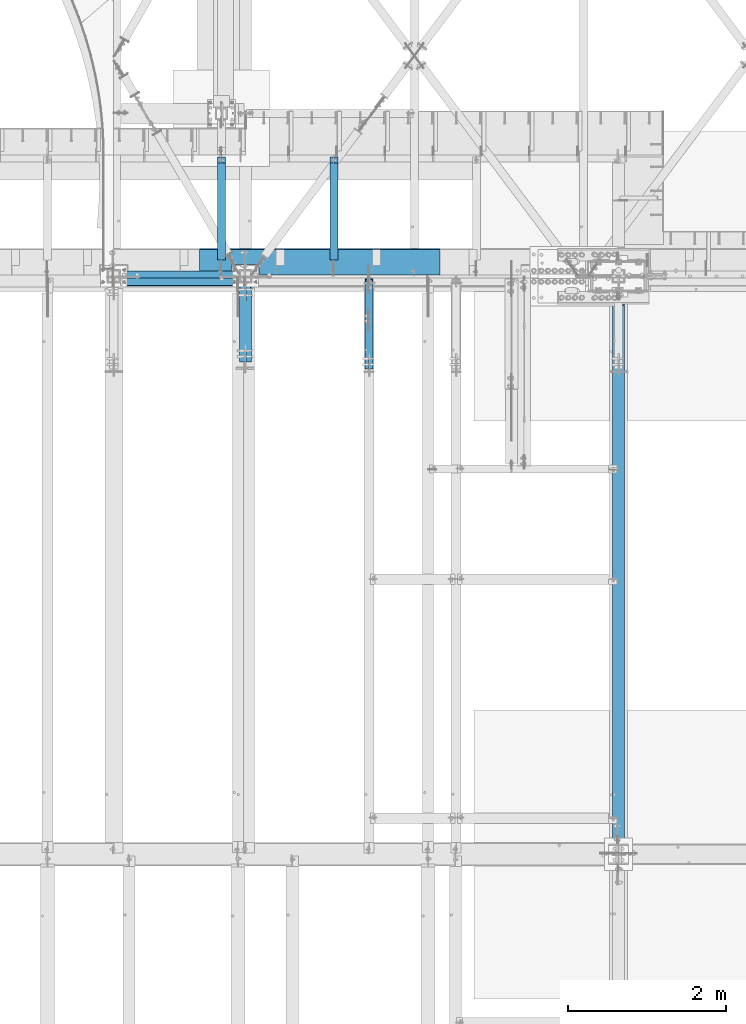
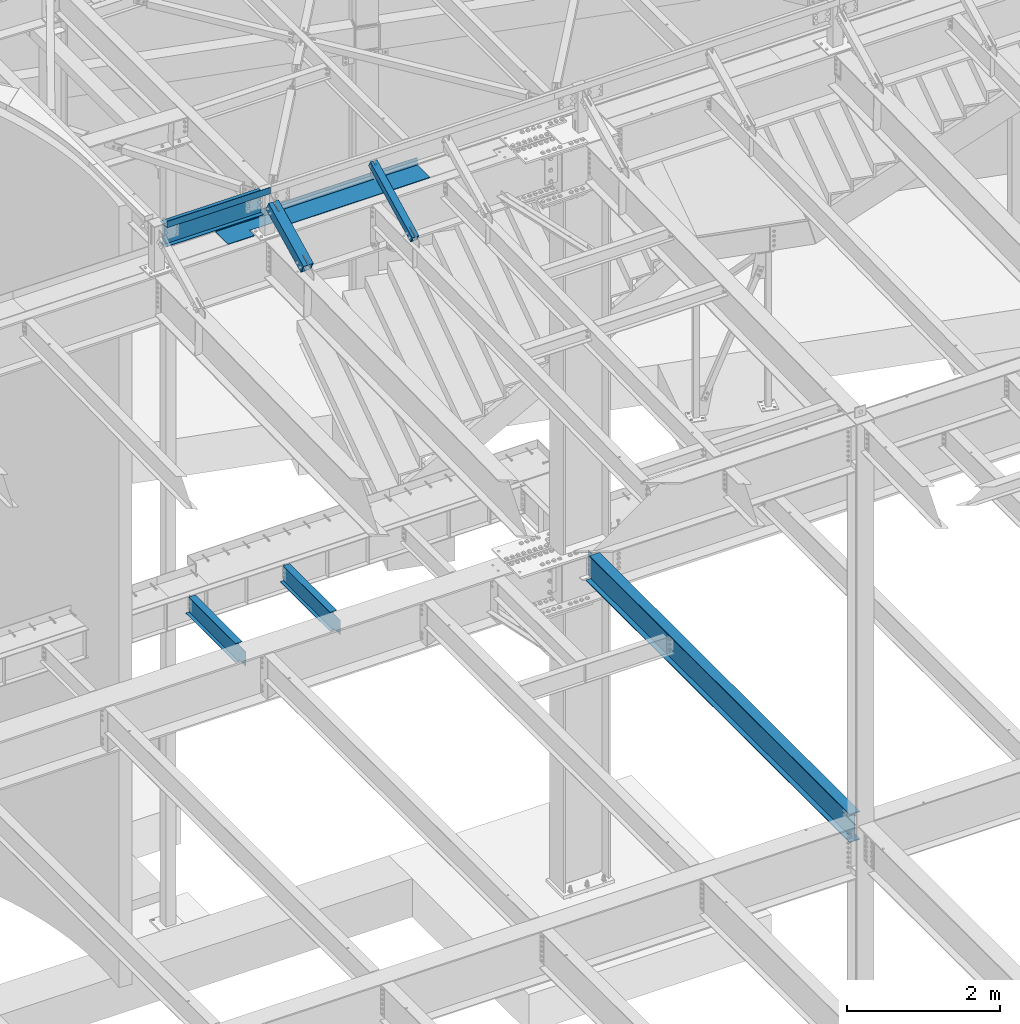
# One storey, part 1144 of 1763: 6 beams, 2 members, 7 elements without a shape of their own.
"""IFC2X3 building model written with IfcOpenShell, lengths in millimetres."""

from ifc_helpers import new_model, si_unit, frame, origin_with_axes, place, context, subcontext, project, spatial, faceted_brep, material, type_object, element, aggregate, save


model = new_model("IFC2X3")

# Units and contexts
model_context = context("Model", 3, precision=1e-05, world=origin_with_axes())
body_context = subcontext(model_context, "Body", "Model", "MODEL_VIEW")
ifc_project = project(units=[si_unit("LENGTHUNIT", "METRE", prefix="MILLI"), si_unit("AREAUNIT", "SQUARE_METRE"), si_unit("VOLUMEUNIT", "CUBIC_METRE"), si_unit("MASSUNIT", "GRAM", prefix="KILO"), si_unit("TIMEUNIT", "SECOND"), si_unit("PLANEANGLEUNIT", "RADIAN"), si_unit("SOLIDANGLEUNIT", "STERADIAN"), si_unit("THERMODYNAMICTEMPERATUREUNIT", "DEGREE_CELSIUS"), si_unit("LUMINOUSINTENSITYUNIT", "LUMEN")], contexts=[model_context])

# Site, building, storey
site_placement = place(None, origin_with_axes())
site = spatial("IfcSite", under=ifc_project, at=site_placement, CompositionType="ELEMENT")
building_placement = place(site_placement, origin_with_axes())
building = spatial("IfcBuilding", under=site, at=building_placement, Name="Undefined", CompositionType="ELEMENT")
storey_placement = place(building_placement, origin_with_axes())
storey = spatial("IfcBuildingStorey", under=building, at=storey_placement, Name="Undefined", CompositionType="ELEMENT", Elevation=0.0)

# Assembly, beam
assembly_1_placement = place(storey_placement, origin_with_axes())
assembly_1 = element("IfcElementAssembly", 1, at=assembly_1_placement, inside=storey, Name="BEAM", AssemblyPlace="NOTDEFINED", PredefinedType="RIGID_FRAME")
ifc_material_1 = material(Name="STEEL/A36")
beam_type_1 = type_object("IfcBeamType", PredefinedType="NOTDEFINED")
beam_1_placement = place(assembly_1_placement, frame((-40470.4887217781, 52101.75, 12449.175), z_axis=(-1.0, 0.0, 0.0), x_axis=(0.0, -1.0, 0.0)))
beam_1 = element("IfcBeam", 2, at=beam_1_placement, type_object=beam_type_1, material=ifc_material_1, Name="BENT_PLATE", context=body_context, shape_type="Brep", body=[
    faceted_brep([(0.0, -3.17499999999927, -779.1495), (0.0, -3.17499999999927, 779.1495), (0.0, 3.17499999999927, 779.1495), (0.0, 3.17499999999927, -779.1495), (95.2499984741153, 3.17499999999927, 779.1495), (95.2499984741153, 3.17499999999927, -779.1495), (101.599998474121, -3.17499999999927, -779.1495), (101.599998474121, -3.17499999999927, 779.1495), (95.2499984741153, 98.4249984741218, 779.1495), (95.2499984741153, 98.4249984741218, -779.1495), (101.599998474121, 98.4249984741218, 779.1495), (101.599998474121, 98.4249984741218, -779.1495)], [[[0, 1, 2, 3]], [[3, 2, 4, 5]], [[1, 0, 6, 7]], [[5, 4, 8, 9]], [[4, 2, 1, 7, 10, 8]], [[7, 6, 11, 10]], [[6, 0, 3, 5, 9, 11]], [[10, 11, 9, 8]]]),
])

# Assembly, member
assembly_2_placement = place(storey_placement, origin_with_axes())
assembly_2 = element("IfcElementAssembly", 3, at=assembly_2_placement, inside=storey, Name="BEAM", AssemblyPlace="NOTDEFINED", PredefinedType="RIGID_FRAME")
ifc_material_2 = material()
member_type_1 = type_object("IfcMemberType", Name="HSS4X4X1/2", PredefinedType="NOTDEFINED")
member_1_placement = place(assembly_2_placement, frame((-38107.8885203322, 50822.4762411655, 11720.6381213767), z_axis=(-1.0, 0.0, 0.0), x_axis=(0.0, 0.894427191199916, 0.447213595099959)))
member_1 = element("IfcMember", 4, at=member_1_placement, type_object=member_type_1, material=ifc_material_2, Name="BEAM", ObjectType="HSS4X4X1/2", context=body_context, shape_type="Brep", body=[
    faceted_brep([(166.342448712421, -50.8000000002612, 7.93750000025466), (166.342448712407, -38.100000000255, 7.93750000025466), (317.154945941751, -38.1000000004733, 7.93750000025466), (317.154945941787, -50.8000000004795, 7.93750000025466), (320.192495686126, -38.1000000004788, 7.33329378956478), (320.192495686155, -50.8000000004849, 7.33329378956478), (322.767606017376, -38.1000000004806, 5.61266007592349), (322.767606017405, -50.8000000004849, 5.61266007592349), (324.488239731007, -38.1000000004842, 3.03754974465119), (324.488239731028, -50.800000000494, 3.03754974465119), (317.154945941773, -50.8000000004795, -7.93749999987267), (317.154945941751, -38.1000000004715, -7.93749999987267), (166.342448712407, -38.100000000255, -7.93749999974898), (166.342448712421, -50.8000000002612, -7.93749999974898), (320.192495686155, -50.8000000004831, -7.33329378918279), (320.192495686126, -38.1000000004769, -7.33329378918279), (322.767606017391, -50.8000000004868, -5.61266007554514), (322.767606017376, -38.1000000004806, -5.61266007554514), (324.488239731028, -50.800000000494, -3.03754974427284), (324.488239731007, -38.1000000004842, -3.03754974427284), (325.092445941715, -50.8000000004904, 2.5465851649642e-10), (325.092445941693, -38.1000000004842, 2.5465851649642e-10), (166.342448712276, 38.0999999997875, 7.93750000025466), (166.342448712254, 50.7999999997955, 7.93750000025466), (317.154945941591, 50.7999999995791, 7.93750000025466), (317.15494594162, 38.0999999995711, 7.93750000025466), (320.192495685966, 50.7999999995736, 7.33329378956478), (320.192495685995, 38.0999999995693, 7.33329378956478), (322.767606017216, 50.7999999995718, 5.61266007592349), (322.767606017245, 38.0999999995638, 5.61266007592349), (324.488239730847, 50.7999999995682, 3.03754974465119), (324.488239730868, 38.0999999995638, 3.03754974465119), (317.154945941606, 38.0999999995693, -7.93749999987267), (317.154945941591, 50.7999999995791, -7.93749999987267), (166.342448712254, 50.7999999997955, -7.93749999974898), (166.342448712276, 38.0999999997875, -7.93749999974898), (320.19249568598, 38.0999999995674, -7.33329378918279), (320.192495685966, 50.7999999995754, -7.33329378918279), (322.767606017245, 38.0999999995638, -5.61266007554514), (322.767606017209, 50.79999999957, -5.61266007554514), (324.488239730861, 38.0999999995602, -3.03754974427284), (324.488239730847, 50.7999999995682, -3.03754974427284), (325.092445941555, 38.0999999995583, 2.5465851649642e-10), (325.092445941533, 50.7999999995682, 2.5465851649642e-10), (166.342448712407, -38.100000000255, 38.0999999999985), (166.342448712276, 38.0999999997875, 38.0999999999985), (1394.22226894266, 38.0999999980304, 38.0999999999985), (1394.2222689429, -38.1000000020122, 38.0999999999985), (1277.08025779721, 50.7999999982076, -7.9375), (1394.22226894262, 50.799999998042, -7.9375), (1394.22226894262, 50.799999998042, -50.7999999999993), (166.342448712254, 50.7999999997955, -50.7999999999993), (166.342448712254, 50.7999999997955, 50.7999999999993), (1394.22226894262, 50.799999998042, 50.7999999999993), (1394.22226894262, 50.799999998042, 7.9375), (1277.08025779721, 50.7999999982076, 7.9375), (1394.22226894266, 38.0999999980304, 7.9375), (1283.4302577901, 38.0999999981887, 7.9375), (1283.4302577901, 38.0999999981887, -7.9375), (1394.22226894266, 38.0999999980304, -7.9375), (166.342448712276, 38.0999999997875, -38.0999999999985), (166.342448712407, -38.100000000255, -38.0999999999985), (1394.2222689429, -38.1000000020122, -38.0999999999985), (1394.22226894266, 38.0999999980304, -38.0999999999985), (1327.88025774027, -50.8000000019219, -7.9375), (1321.53025774739, -38.1000000019103, -7.9375), (1321.53025774739, -38.1000000019103, 7.9375), (1327.88025774027, -50.8000000019219, 7.9375), (1394.22226894295, -50.8000000020184, -7.9375), (1394.2222689429, -38.1000000020122, -7.9375), (1394.22226894295, -50.8000000020184, -50.7999999999993), (166.342448712421, -50.8000000002612, -50.7999999999993), (1394.2222689429, -38.1000000020122, 7.9375), (1394.22226894295, -50.8000000020184, 7.9375), (1394.22226894295, -50.8000000020184, 50.7999999999993), (166.342448712421, -50.8000000002612, 50.7999999999993)], [[[0, 1, 2, 3]], [[3, 2, 4, 5]], [[5, 4, 6, 7]], [[7, 6, 8, 9]], [[10, 11, 12, 13]], [[14, 15, 11, 10]], [[16, 17, 15, 14]], [[18, 19, 17, 16]], [[20, 21, 19, 18]], [[9, 8, 21, 20]], [[22, 23, 24, 25]], [[25, 24, 26, 27]], [[27, 26, 28, 29]], [[29, 28, 30, 31]], [[32, 33, 34, 35]], [[36, 37, 33, 32]], [[38, 39, 37, 36]], [[40, 41, 39, 38]], [[42, 43, 41, 40]], [[31, 30, 43, 42]], [[44, 45, 46, 47]], [[48, 49, 50, 51, 34, 33, 37, 39, 41, 43, 30, 28, 26, 24, 23, 52, 53, 54, 55]], [[56, 57, 55, 54]], [[58, 48, 55, 57]], [[59, 49, 48, 58]], [[60, 61, 62, 63]], [[64, 65, 66, 67]], [[68, 69, 65, 64]], [[70, 50, 49, 59, 63, 62, 69, 68]], [[71, 51, 50, 70]], [[61, 60, 35, 34, 51, 71, 13, 12]], [[65, 69, 62, 61, 12, 11, 15, 17, 19, 21, 8, 6, 4, 2, 1, 44, 47, 72, 66]], [[73, 67, 66, 72]], [[47, 46, 56, 54, 53, 74, 73, 72]], [[52, 75, 74, 53]], [[74, 75, 0, 3, 5, 7, 9, 20, 18, 16, 14, 10, 13, 71, 70, 68, 64, 67, 73]], [[75, 52, 23, 22, 45, 44, 1, 0]], [[46, 45, 22, 25, 27, 29, 31, 42, 40, 38, 36, 32, 35, 60, 63, 59, 58, 57, 56]]]),
])
aggregate(assembly_2, [member_1])

# Beam
ifc_material_3 = material(Name="STEEL/A992")
beam_type_2 = type_object("IfcBeamType", Name="W14X22", PredefinedType="NOTDEFINED")
beam_2_placement = place(assembly_1_placement, frame((-41338.5382217802, 52120.8, 12271.375), z_axis=(0.0, 0.0, 1.0), x_axis=(1.0, 0.0, 0.0)))
beam_2 = element("IfcBeam", 5, at=beam_2_placement, type_object=beam_type_2, material=ifc_material_3, Name="BEAM", ObjectType="W14X22", context=body_context, shape_type="Brep", body=[
    faceted_brep([(88.8999999999942, 63.5, -174.625), (88.8999999999942, 63.5, -166.6875), (1577.34860433371, 63.5, -166.6875), (1577.34860433371, 63.5, -174.625), (88.8999999999942, 3.17500000000291, -166.6875), (1577.34860433371, 3.17500000000291, -166.6875), (88.8999999999942, 3.17500000000291, 166.6875), (1577.34860433371, 3.17500000000291, 166.6875), (88.8999999999942, 63.5, 166.6875), (1577.34860433371, 63.5, 166.6875), (88.8999999999942, 63.5, 174.625), (1577.34860433371, 63.5, 174.625), (88.8999999999942, -63.5, 174.625), (1577.34860433371, -63.5, 174.625), (88.8999999999942, -63.5, 166.6875), (1577.34860433371, -63.5, 166.6875), (88.8999999999942, -3.17500000000291, 166.6875), (1577.34860433371, -3.17500000000291, 166.6875), (88.8999999999942, -3.17500000000291, -166.6875), (1577.34860433371, -3.17500000000291, -166.6875), (88.8999999999942, -63.5, -166.6875), (1577.34860433371, -63.5, -166.6875), (88.8999999999942, -63.5, -174.625), (1577.34860433371, -63.5, -174.625)], [[[0, 1, 2, 3]], [[1, 4, 5, 2]], [[4, 6, 7, 5]], [[6, 8, 9, 7]], [[8, 10, 11, 9]], [[10, 12, 13, 11]], [[12, 14, 15, 13]], [[14, 16, 17, 15]], [[16, 18, 19, 17]], [[18, 20, 21, 19]], [[20, 22, 23, 21]], [[22, 0, 3, 23]], [[5, 7, 9, 11, 13, 15, 17, 19, 21, 23, 3, 2]], [[22, 20, 18, 16, 14, 12, 10, 8, 6, 4, 1, 0]]]),
])

aggregate(assembly_1, [beam_1, beam_2])

# Assembly, beam
assembly_3_placement = place(storey_placement, origin_with_axes())
assembly_3 = element("IfcElementAssembly", 6, at=assembly_3_placement, inside=storey, Name="BEAM", AssemblyPlace="NOTDEFINED", PredefinedType="RIGID_FRAME")
beam_type_3 = type_object("IfcBeamType", PredefinedType="NOTDEFINED")
beam_3_placement = place(assembly_3_placement, frame((-38731.2617736983, 52133.5000002128, 11752.2624917654), z_axis=(-1.0, 0.0, 0.0), x_axis=(0.0, 1.0, 0.0)))
beam_3 = element("IfcBeam", 7, at=beam_3_placement, type_object=beam_type_3, material=ifc_material_1, Name="BENT_PLATE", context=body_context, shape_type="Brep", body=[
    faceted_brep([(133.349999999999, -4.76250000000073, 763.227837646504), (133.349999999999, 4.76250000000073, 763.227837646504), (0.0, 4.76250000000073, 763.227837646504), (0.0, -4.76250000000073, 763.227837646504), (133.349999999999, -4.76250000000073, 1118.82784375002), (133.349999999999, 4.76250000000073, 1118.82784375002), (0.0, -4.76250000000073, 1118.82784375002), (0.0, 4.76250000000073, 1118.82784375002), (327.024987792967, -4.76250000000073, 1524.00000000001), (327.024987792975, -4.76250000000073, -1524.0), (327.024987792975, -122.237499999999, -1524.0), (327.024987792975, -122.237499999999, 1524.0), (336.549987792969, 4.76250000000073, 1524.0), (0.0, 4.76249999999982, 1524.0), (0.0, -4.76249999999982, 1524.0), (336.549987792969, -122.237499999999, 1524.0), (336.549987792969, 4.76250000000073, -1524.0), (336.549987792969, -122.237499999999, -1524.0), (0.0, -4.76249999999982, -1524.0), (0.0, 4.76249999999982, -1524.0)], [[[0, 1, 2, 3]], [[4, 5, 1, 0]], [[6, 7, 5, 4]], [[8, 9, 10, 11]], [[12, 13, 14, 8, 11, 15]], [[16, 12, 15, 17]], [[11, 10, 17, 15]], [[9, 18, 19, 16, 17, 10]], [[19, 18, 3, 2]], [[13, 12, 16, 19, 2, 1, 5, 7]], [[14, 13, 7, 6]], [[3, 18, 9, 8, 14, 6, 4, 0]]]),
])
aggregate(assembly_3, [beam_3])

# Assembly, member
assembly_4_placement = place(storey_placement, origin_with_axes())
assembly_4 = element("IfcElementAssembly", 8, at=assembly_4_placement, inside=storey, Name="BEAM", AssemblyPlace="NOTDEFINED", PredefinedType="RIGID_FRAME")
member_type_2 = type_object("IfcMemberType", Name="HSS6X6X3/8", PredefinedType="NOTDEFINED")
member_2_placement = place(assembly_4_placement, frame((-39672.2896174484, 50875.4398145204, 11721.7339194219), z_axis=(-1.0, 0.0, 0.0), x_axis=(0.0, 0.894427191199916, 0.447213595099959)))
member_2 = element("IfcMember", 9, at=member_2_placement, type_object=member_type_2, material=ifc_material_2, Name="BEAM", ObjectType="HSS6X6X3/8", context=body_context, shape_type="Brep", body=[
    faceted_brep([(1240.66275569003, -76.2000000018161, -7.9375), (1240.66275569002, -66.6750000018073, -7.9375), (1089.8502556844, -66.6750000015927, -7.9375), (1089.85025568441, -76.2000000015978, -7.9375), (1086.81270594003, -66.6750000015854, -7.33329378930648), (1086.81270594004, -76.2000000015923, -7.33329378930648), (1084.23759560877, -66.6750000015854, -5.61266007566883), (1084.23759560879, -76.2000000015905, -5.61266007566883), (1082.51696189515, -66.6750000015818, -3.03754974439653), (1082.51696189517, -76.2000000015869, -3.03754974439653), (1081.91275568446, -66.67500000158, 0.0), (1081.91275568448, -76.2000000015869, 0.0), (1082.51696189515, -66.6750000015818, 3.03754974439653), (1082.51696189517, -76.2000000015869, 3.03754974439653), (1084.23759560877, -66.6750000015854, 5.61266007566883), (1084.23759560879, -76.2000000015905, 5.61266007566883), (1086.81270594003, -66.6750000015854, 7.33329378930648), (1086.81270594004, -76.2000000015923, 7.33329378930648), (1089.8502556844, -66.6750000015927, 7.9375), (1089.85025568441, -76.2000000015978, 7.9375), (1240.66275569003, -76.2000000018161, 7.9375), (1240.66275569002, -66.6750000018073, 7.9375), (1240.6627556898, 66.6749999982694, -7.9375), (1240.66275568979, 76.1999999982745, -7.9375), (1089.85025568414, 76.199999998491, -7.9375), (1089.85025568416, 66.6749999984859, -7.9375), (1086.81270593977, 76.1999999984964, -7.33329378930648), (1086.81270593978, 66.6749999984877, -7.33329378930648), (1084.23759560852, 76.1999999985019, -5.61266007566883), (1084.23759560853, 66.6749999984931, -5.61266007566883), (1082.51696189489, 76.1999999985019, -3.03754974439653), (1082.5169618949, 66.674999998495, -3.03754974439653), (1081.91275568419, 76.1999999984982, 0.0), (1081.91275568422, 66.6749999984968, 0.0), (1082.51696189489, 76.1999999985019, 3.03754974439653), (1082.5169618949, 66.674999998495, 3.03754974439653), (1084.23759560852, 76.1999999985019, 5.61266007566883), (1084.23759560853, 66.6749999984931, 5.61266007566883), (1086.81270593977, 76.1999999984964, 7.33329378930648), (1086.81270593978, 66.6749999984877, 7.33329378930648), (1089.85025568414, 76.199999998491, 7.9375), (1089.85025568416, 66.6749999984859, 7.9375), (1240.6627556898, 66.6749999982694, 7.9375), (1240.66275568979, 76.1999999982745, 7.9375), (219.883454288814, -66.6750000003503, 66.6750000000029), (219.883454288596, 66.6749999997282, 66.6750000000029), (1240.6627556898, 66.6749999982694, 66.6750000000029), (1240.66275569002, -66.6750000018073, 66.6750000000029), (1240.66275569002, -66.6750000018073, -66.6750000000029), (219.883454288814, -66.6750000003503, -66.6750000000029), (219.883454288814, -66.6750000003503, -7.9375), (370.6959556441, -66.6750000005632, -7.9375), (373.733505388474, -66.6750000005704, -7.33329378930648), (376.308615719718, -66.6750000005759, -5.61266007566883), (378.029249433355, -66.6750000005759, -3.03754974439653), (378.633455644042, -66.6750000005759, 0.0), (378.029249433355, -66.6750000005759, 3.03754974439653), (376.308615719718, -66.6750000005759, 5.61266007566883), (373.733505388474, -66.6750000005704, 7.33329378930648), (370.6959556441, -66.6750000005632, 7.9375), (219.883454288814, -66.6750000003503, 7.9375), (219.883454288596, 66.6749999997282, -66.6750000000029), (1240.6627556898, 66.6749999982694, -66.6750000000029), (219.883454288596, 66.6749999997282, 7.9375), (219.883454288589, 76.1999999997333, 7.9375), (370.695955643838, 76.1999999995151, 7.9375), (370.69595564386, 66.6749999995136, 7.9375), (373.733505388213, 76.1999999995132, 7.33329378930648), (373.733505388234, 66.6749999995063, 7.33329378930648), (376.308615719463, 76.1999999995078, 5.61266007566883), (376.308615719485, 66.6749999995045, 5.61266007566883), (378.029249433086, 76.1999999995078, 3.03754974439653), (378.029249433108, 66.6749999995027, 3.03754974439653), (378.633455643772, 76.1999999995041, 0.0), (378.633455643794, 66.6749999995009, 0.0), (378.029249433086, 76.1999999995078, -3.03754974439653), (378.029249433108, 66.6749999995027, -3.03754974439653), (376.308615719463, 76.1999999995078, -5.61266007566883), (376.308615719485, 66.6749999995045, -5.61266007566883), (373.733505388213, 76.1999999995132, -7.33329378930648), (373.733505388234, 66.6749999995063, -7.33329378930648), (370.695955643838, 76.1999999995151, -7.9375), (370.69595564386, 66.6749999995136, -7.9375), (219.883454288589, 76.1999999997333, -7.9375), (219.883454288596, 66.6749999997282, -7.9375), (219.883454288589, 76.1999999997333, -76.1999999999971), (219.883454288829, -76.2000000003554, -76.1999999999971), (219.883454288829, -76.2000000003554, -7.9375), (370.695955644114, -76.2000000005701, -7.9375), (373.733505388489, -76.2000000005755, -7.33329378930648), (376.308615719739, -76.200000000581, -5.61266007566883), (378.02924943337, -76.2000000005828, -3.03754974439653), (378.633455644056, -76.200000000581, 0.0), (378.02924943337, -76.2000000005828, 3.03754974439653), (376.308615719739, -76.200000000581, 5.61266007566883), (373.733505388489, -76.2000000005755, 7.33329378930648), (370.695955644114, -76.2000000005701, 7.9375), (219.883454288829, -76.2000000003554, 7.9375), (219.883454288829, -76.2000000003554, 76.1999999999971), (219.883454288589, 76.1999999997333, 76.1999999999971), (1240.66275569003, -76.2000000018161, 76.1999999999971), (1240.66275568979, 76.1999999982745, 76.1999999999971), (1240.66275568979, 76.1999999982745, -76.1999999999971), (1240.66275569003, -76.2000000018161, -76.1999999999971)], [[[0, 1, 2, 3]], [[3, 2, 4, 5]], [[5, 4, 6, 7]], [[7, 6, 8, 9]], [[9, 8, 10, 11]], [[11, 10, 12, 13]], [[13, 12, 14, 15]], [[15, 14, 16, 17]], [[17, 16, 18, 19]], [[20, 19, 18, 21]], [[22, 23, 24, 25]], [[25, 24, 26, 27]], [[27, 26, 28, 29]], [[29, 28, 30, 31]], [[31, 30, 32, 33]], [[33, 32, 34, 35]], [[35, 34, 36, 37]], [[37, 36, 38, 39]], [[39, 38, 40, 41]], [[42, 41, 40, 43]], [[44, 45, 46, 47]], [[16, 14, 12, 10, 8, 6, 4, 2, 1, 48, 49, 50, 51, 52, 53, 54, 55, 56, 57, 58, 59, 60, 44, 47, 21, 18]], [[61, 49, 48, 62]], [[63, 64, 65, 66]], [[66, 65, 67, 68]], [[68, 67, 69, 70]], [[70, 69, 71, 72]], [[72, 71, 73, 74]], [[74, 73, 75, 76]], [[76, 75, 77, 78]], [[78, 77, 79, 80]], [[80, 79, 81, 82]], [[82, 81, 83, 84]], [[49, 61, 84, 83, 85, 86, 87, 50]], [[88, 51, 50, 87]], [[89, 52, 51, 88]], [[90, 53, 52, 89]], [[91, 54, 53, 90]], [[92, 55, 54, 91]], [[93, 56, 55, 92]], [[94, 57, 56, 93]], [[95, 58, 57, 94]], [[96, 59, 58, 95]], [[97, 60, 59, 96]], [[98, 99, 64, 63, 45, 44, 60, 97]], [[99, 98, 100, 101]], [[47, 46, 42, 43, 101, 100, 20, 21]], [[38, 36, 34, 32, 30, 28, 26, 24, 23, 102, 85, 83, 81, 79, 77, 75, 73, 71, 69, 67, 65, 64, 99, 101, 43, 40]], [[86, 85, 102, 103]], [[100, 98, 97, 96, 95, 94, 93, 92, 91, 90, 89, 88, 87, 86, 103, 0, 3, 5, 7, 9, 11, 13, 15, 17, 19, 20]], [[103, 102, 23, 22, 62, 48, 1, 0]], [[46, 45, 63, 66, 68, 70, 72, 74, 76, 78, 80, 82, 84, 61, 62, 22, 25, 27, 29, 31, 33, 35, 37, 39, 41, 42]]]),
])
aggregate(assembly_4, [member_2])

# Assembly, beam
assembly_5_placement = place(storey_placement, origin_with_axes())
assembly_5 = element("IfcElementAssembly", 10, at=assembly_5_placement, inside=storey, Name="BEAM", AssemblyPlace="NOTDEFINED", PredefinedType="RIGID_FRAME")
beam_type_4 = type_object("IfcBeamType", Name="W12X16", PredefinedType="NOTDEFINED")
beam_4_placement = place(assembly_5_placement, frame((-38552.800815365, 52120.8, 5041.9), z_axis=(0.0, 0.0, 1.0), x_axis=(0.0, 1.0, 0.0)))
beam_4 = element("IfcBeam", 11, at=beam_4_placement, type_object=beam_type_4, material=ifc_material_3, Name="BEAM", ObjectType="W12X16", context=body_context, shape_type="Brep", body=[
    faceted_brep([(20.6374999999971, -3.17500000000291, -114.3), (20.6374999999971, 3.17500000000291, -114.3), (192.087500190733, 3.17500000000291, -114.3), (192.087500190733, -3.17500000000291, -114.3), (196.94757970878, 3.17500000000291, -115.266729922588), (196.94757970878, -3.17500000000291, -115.266729922588), (201.067756176933, 3.17500000000291, -118.019743823066), (201.067756176933, -3.17500000000291, -118.019743823066), (203.820770077407, 3.17500000000291, -122.13992029122), (203.820770077407, -3.17500000000291, -122.13992029122), (204.787499999999, -3.17500000000291, -126.999999809265), (204.787499999999, 3.17500000000291, -126.999999809265), (204.787499999999, 3.17500000000291, -146.05), (204.787499999999, 50.8000000000029, -146.05), (204.787499999999, 50.8000000000029, -152.4), (204.787499999999, -50.8000000000029, -152.4), (204.787499999999, -50.8000000000029, -146.05), (204.787499999999, -3.17500000000291, -146.05), (1431.13125000001, 50.8000000000029, 146.05), (1431.13125000001, 3.17500000000291, 146.05), (204.787499999999, 3.17500000000291, 146.05), (204.787499999999, 50.8000000000029, 146.05), (192.087500190733, -3.17500000000291, 114.3), (192.087500190733, 3.17500000000291, 114.3), (20.6374999999971, 3.17500000000291, 114.3), (20.6374999999971, -3.17500000000291, 114.3), (196.94757970878, -3.17500000000291, 115.266729922588), (196.94757970878, 3.17500000000291, 115.266729922588), (201.067756176933, -3.17500000000291, 118.019743823066), (201.067756176933, 3.17500000000291, 118.019743823066), (203.820770077407, -3.17500000000291, 122.13992029122), (203.820770077407, 3.17500000000291, 122.13992029122), (204.787499999999, -3.17500000000291, 126.999999809265), (204.787499999999, 3.17500000000291, 126.999999809265), (1431.13125000001, -50.8000000000029, 152.4), (1431.13125000001, 50.8000000000029, 152.4), (204.787499999999, 50.8000000000029, 152.4), (204.787499999999, -50.8000000000029, 152.4), (1431.13125000001, -50.8000000000029, 146.05), (204.787499999999, -50.8000000000029, 146.05), (1431.13125000001, -3.17500000000291, 146.05), (204.787499999999, -3.17500000000291, 146.05), (1431.13125000001, -3.17500000000291, 139.440001487732), (1431.13125000001, 3.17500000000291, 139.440001487732), (1432.0979799226, -3.17500000000291, 134.579921969686), (1432.0979799226, 3.17500000000291, 134.579921969686), (1434.85099382307, -3.17500000000291, 130.459745501533), (1434.85099382307, 3.17500000000291, 130.459745501533), (1438.97117029122, -3.17500000000291, 127.706731601054), (1438.97117029122, 3.17500000000291, 127.706731601054), (1443.83124980927, -3.17500000000291, 126.740001678467), (1443.83124980927, 3.17500000000291, 126.740001678467), (1507.33125, -3.17500000000291, 126.740001678467), (1507.33125, 3.17500000000291, 126.740001678467), (1507.33125, -3.17500000000291, -146.05), (1507.33125, -50.8000000000029, -146.05), (1507.33125, -50.8000000000029, -152.4), (1507.33125, 50.8000000000029, -152.4), (1507.33125, 50.8000000000029, -146.05), (1507.33125, 3.17500000000291, -146.05)], [[[0, 1, 2, 3]], [[3, 2, 4, 5]], [[5, 4, 6, 7]], [[7, 6, 8, 9]], [[10, 11, 12, 13, 14, 15, 16, 17]], [[9, 8, 11, 10]], [[18, 19, 20, 21]], [[22, 23, 24, 25]], [[26, 27, 23, 22]], [[28, 29, 27, 26]], [[30, 31, 29, 28]], [[32, 33, 31, 30]], [[34, 35, 36, 37]], [[38, 34, 37, 39]], [[40, 38, 39, 41]], [[37, 36, 21, 20, 33, 32, 41, 39]], [[35, 18, 21, 36]], [[34, 38, 40, 42, 43, 19, 18, 35]], [[44, 45, 43, 42]], [[46, 47, 45, 44]], [[48, 49, 47, 46]], [[50, 51, 49, 48]], [[52, 53, 51, 50]], [[54, 55, 56, 57, 58, 59, 53, 52]], [[55, 54, 17, 16]], [[56, 55, 16, 15]], [[57, 56, 15, 14]], [[58, 57, 14, 13]], [[59, 58, 13, 12]], [[6, 4, 2, 1, 24, 23, 27, 29, 31, 33, 20, 19, 43, 45, 47, 49, 51, 53, 59, 12, 11, 8]], [[25, 24, 1, 0]], [[54, 52, 50, 48, 46, 44, 42, 40, 41, 32, 30, 28, 26, 22, 25, 0, 3, 5, 7, 9, 10, 17]]]),
])
aggregate(assembly_5, [beam_4])

assembly_6_placement = place(storey_placement, origin_with_axes())
assembly_6 = element("IfcElementAssembly", 12, at=assembly_6_placement, inside=storey, Name="BEAM", AssemblyPlace="NOTDEFINED", PredefinedType="RIGID_FRAME")
beam_5_placement = place(assembly_6_placement, frame((-39977.1190440317, 52120.8, 5041.9), z_axis=(0.0, 0.0, 1.0), x_axis=(0.0, 1.0, 0.0)))
beam_5 = element("IfcBeam", 13, at=beam_5_placement, type_object=beam_type_4, material=ifc_material_3, Name="BEAM", ObjectType="W12X16", context=body_context, shape_type="Brep", body=[
    faceted_brep([(20.6374999999971, -3.17500000000291, -114.3), (20.6374999999971, 3.17500000000291, -114.3), (192.087500190733, 3.17500000000291, -114.3), (192.087500190733, -3.17500000000291, -114.3), (196.94757970878, 3.17500000000291, -115.266729922588), (196.94757970878, -3.17500000000291, -115.266729922588), (201.067756176933, 3.17500000000291, -118.019743823066), (201.067756176933, -3.17500000000291, -118.019743823066), (203.820770077407, 3.17500000000291, -122.13992029122), (203.820770077407, -3.17500000000291, -122.13992029122), (204.787499999999, -3.17500000000291, -126.999999809265), (204.787499999999, 3.17500000000291, -126.999999809265), (204.787499999999, 3.17500000000291, -146.05), (204.787499999999, 50.8000000000029, -146.05), (204.787499999999, 50.8000000000029, -152.4), (204.787499999999, -50.8000000000029, -152.4), (204.787499999999, -50.8000000000029, -146.05), (204.787499999999, -3.17500000000291, -146.05), (1431.13125000001, 50.8000000000029, 146.05), (1431.13125000001, 3.17500000000291, 146.05), (204.787499999999, 3.17500000000291, 146.05), (204.787499999999, 50.8000000000029, 146.05), (192.087500190733, -3.17500000000291, 114.3), (192.087500190733, 3.17500000000291, 114.3), (20.6374999999971, 3.17500000000291, 114.3), (20.6374999999971, -3.17500000000291, 114.3), (196.94757970878, -3.17500000000291, 115.266729922588), (196.94757970878, 3.17500000000291, 115.266729922588), (201.067756176933, -3.17500000000291, 118.019743823066), (201.067756176933, 3.17500000000291, 118.019743823066), (203.820770077407, -3.17500000000291, 122.13992029122), (203.820770077407, 3.17500000000291, 122.13992029122), (204.787499999999, -3.17500000000291, 126.999999809265), (204.787499999999, 3.17500000000291, 126.999999809265), (1431.13125000001, -50.8000000000029, 152.4), (1431.13125000001, 50.8000000000029, 152.4), (204.787499999999, 50.8000000000029, 152.4), (204.787499999999, -50.8000000000029, 152.4), (1431.13125000001, -50.8000000000029, 146.05), (204.787499999999, -50.8000000000029, 146.05), (1431.13125000001, -3.17500000000291, 146.05), (204.787499999999, -3.17500000000291, 146.05), (1431.13125000001, -3.17500000000291, 139.440001487732), (1431.13125000001, 3.17500000000291, 139.440001487732), (1432.0979799226, -3.17500000000291, 134.579921969686), (1432.0979799226, 3.17500000000291, 134.579921969686), (1434.85099382307, -3.17500000000291, 130.459745501533), (1434.85099382307, 3.17500000000291, 130.459745501533), (1438.97117029122, -3.17500000000291, 127.706731601054), (1438.97117029122, 3.17500000000291, 127.706731601054), (1443.83124980927, -3.17500000000291, 126.740001678467), (1443.83124980927, 3.17500000000291, 126.740001678467), (1507.33125, -3.17500000000291, 126.740001678467), (1507.33125, 3.17500000000291, 126.740001678467), (1507.33125, -3.17500000000291, -146.05), (1507.33125, -50.8000000000029, -146.05), (1507.33125, -50.8000000000029, -152.4), (1507.33125, 50.8000000000029, -152.4), (1507.33125, 50.8000000000029, -146.05), (1507.33125, 3.17500000000291, -146.05)], [[[0, 1, 2, 3]], [[3, 2, 4, 5]], [[5, 4, 6, 7]], [[7, 6, 8, 9]], [[10, 11, 12, 13, 14, 15, 16, 17]], [[9, 8, 11, 10]], [[18, 19, 20, 21]], [[22, 23, 24, 25]], [[26, 27, 23, 22]], [[28, 29, 27, 26]], [[30, 31, 29, 28]], [[32, 33, 31, 30]], [[34, 35, 36, 37]], [[38, 34, 37, 39]], [[40, 38, 39, 41]], [[37, 36, 21, 20, 33, 32, 41, 39]], [[35, 18, 21, 36]], [[34, 38, 40, 42, 43, 19, 18, 35]], [[44, 45, 43, 42]], [[46, 47, 45, 44]], [[48, 49, 47, 46]], [[50, 51, 49, 48]], [[52, 53, 51, 50]], [[54, 55, 56, 57, 58, 59, 53, 52]], [[55, 54, 17, 16]], [[56, 55, 16, 15]], [[57, 56, 15, 14]], [[58, 57, 14, 13]], [[59, 58, 13, 12]], [[6, 4, 2, 1, 24, 23, 27, 29, 31, 33, 20, 19, 43, 45, 47, 49, 51, 53, 59, 12, 11, 8]], [[25, 24, 1, 0]], [[54, 52, 50, 48, 46, 44, 42, 40, 41, 32, 30, 28, 26, 22, 25, 0, 3, 5, 7, 9, 10, 17]]]),
])
aggregate(assembly_6, [beam_5])

assembly_7_placement = place(storey_placement, origin_with_axes())
assembly_7 = element("IfcElementAssembly", 14, at=assembly_7_placement, inside=storey, Name="BEAM", AssemblyPlace="NOTDEFINED", PredefinedType="RIGID_FRAME")
beam_type_5 = type_object("IfcBeamType", Name="W18X40", PredefinedType="NOTDEFINED")
beam_6_placement = place(assembly_7_placement, frame((-34949.8372736984, 44805.6, 4967.2875), z_axis=(0.0, 0.0, 1.0), x_axis=(0.0, 1.0, 0.0)))
beam_6 = element("IfcBeam", 15, at=beam_6_placement, type_object=beam_type_5, material=ifc_material_3, Name="BEAM", ObjectType="W18X40", context=body_context, shape_type="Brep", body=[
    faceted_brep([(6950.07498427558, -76.1999999999971, 214.3125), (6950.07498427558, -3.96875, 214.3125), (6950.30419949691, -3.96875, 213.91549911499), (6950.30419949691, 3.96875, 213.91549911499), (6950.07498427558, 3.96875, 214.3125), (6950.07498427558, 76.1999999999971, 214.3125), (6942.74242301262, 76.1999999999971, 227.0125), (6942.74242301262, -76.1999999999971, 227.0125), (144.462499999994, 76.1999999999971, -214.3125), (144.462499999994, 71.199821507762, -214.3125), (144.462499999994, 3.96875, -214.3125), (7034.81740421003, 3.96875, -214.3125), (7034.81740421003, 76.1999999999971, -214.3125), (6903.46589592936, -3.96875, 204.211830867132), (6903.46589592936, 3.96875, 204.211830867132), (6924.67499999999, 3.96875, 213.91549911499), (6924.67499999999, -3.96875, 213.91549911499), (6900.42798023408, -3.96875, 201.276913128712), (6900.42798023408, 3.96875, 201.276913128712), (6899.9033755815, -3.96875, 197.085557278698), (6899.9033755815, 3.96875, 197.085557278698), (6902.12421911652, -3.96875, 193.492434974088), (6902.12421911652, 3.96875, 193.492434974088), (6906.10778932697, -3.96875, 192.0875), (6906.10778932697, 3.96875, 192.0875), (7105.64999999999, -3.96875, 192.0875), (7105.64999999999, 3.96875, 192.0875), (7105.64999999999, -3.96875, -192.0875), (7105.64999999999, 3.96875, -192.0875), (7015.79178896076, -3.96875, -192.0875), (7015.79178896076, 3.96875, -192.0875), (7011.80821875032, -3.96875, -193.492434974089), (7011.80821875032, 3.96875, -193.492434974089), (7009.58737521528, -3.96875, -197.085557278698), (7009.58737521528, 3.96875, -197.085557278698), (7010.11197986786, -3.96875, -201.276913128712), (7010.11197986786, 3.96875, -201.276913128712), (7013.14989556315, -3.96875, -204.211830867132), (7013.14989556315, 3.96875, -204.211830867132), (7034.35899963378, -3.96875, -213.91549911499), (7034.35899963378, 3.96875, -213.91549911499), (144.462499999994, -76.1999999999971, -227.0125), (144.462499999994, -14.2685700086731, -227.0125), (144.462499999994, -5.73107306084421, -227.0125), (144.462499999994, 71.2001784793538, -227.0125), (144.462499999994, 76.1999999999971, -227.0125), (7042.14959249342, 76.1999999999971, -227.0125), (7042.14959249342, -76.1999999999971, -227.0125), (144.462499999994, -76.1999999999971, -214.3125), (7034.81740421003, -76.1999999999971, -214.3125), (144.462499999994, -3.96875, -214.3125), (144.462499999994, -5.73143003243604, -214.3125), (144.462499999994, -14.268926980265, -214.3125), (7034.81740421003, -3.96875, -214.3125), (144.462499999994, -3.96875, -205.614753375452), (144.462499999994, -3.96875, 214.3125), (144.462499999994, -76.1999999999971, 214.3125), (144.462499999994, -76.1999999999971, 227.0125), (144.462499999994, 76.1999999999971, 227.0125), (144.462499999994, 76.1999999999971, 214.3125), (144.462499999994, 3.96875, 214.3125), (144.462499999994, 3.96875, -205.614530268201)], [[[0, 1, 2, 3, 4, 5, 6, 7]], [[8, 9, 10, 11, 12]], [[13, 14, 15, 16]], [[17, 18, 14, 13]], [[19, 20, 18, 17]], [[21, 22, 20, 19]], [[23, 24, 22, 21]], [[24, 23, 25, 26]], [[25, 27, 28, 26]], [[29, 30, 28, 27]], [[31, 32, 30, 29]], [[33, 34, 32, 31]], [[35, 36, 34, 33]], [[37, 38, 36, 35]], [[38, 37, 39, 40]], [[41, 42, 43, 44, 45, 46, 47]], [[48, 41, 47, 49]], [[50, 51, 52, 48, 49, 53]], [[47, 46, 12, 11, 40, 39, 53, 49]], [[45, 8, 12, 46]], [[44, 43, 42, 41, 48, 52, 51, 50, 54, 55, 56, 57, 58, 59, 60, 61, 10, 9, 8, 45]], [[57, 56, 0, 7]], [[58, 57, 7, 6]], [[59, 58, 6, 5]], [[60, 59, 5, 4]], [[15, 14, 18, 20, 22, 24, 26, 28, 30, 32, 34, 36, 38, 40, 11, 10, 61, 60, 4, 3]], [[16, 15, 3, 2]], [[55, 54, 50, 53, 39, 37, 35, 33, 31, 29, 27, 25, 23, 21, 19, 17, 13, 16, 2, 1]], [[56, 55, 1, 0]]]),
])
aggregate(assembly_7, [beam_6])

save(model, "model.ifc")
